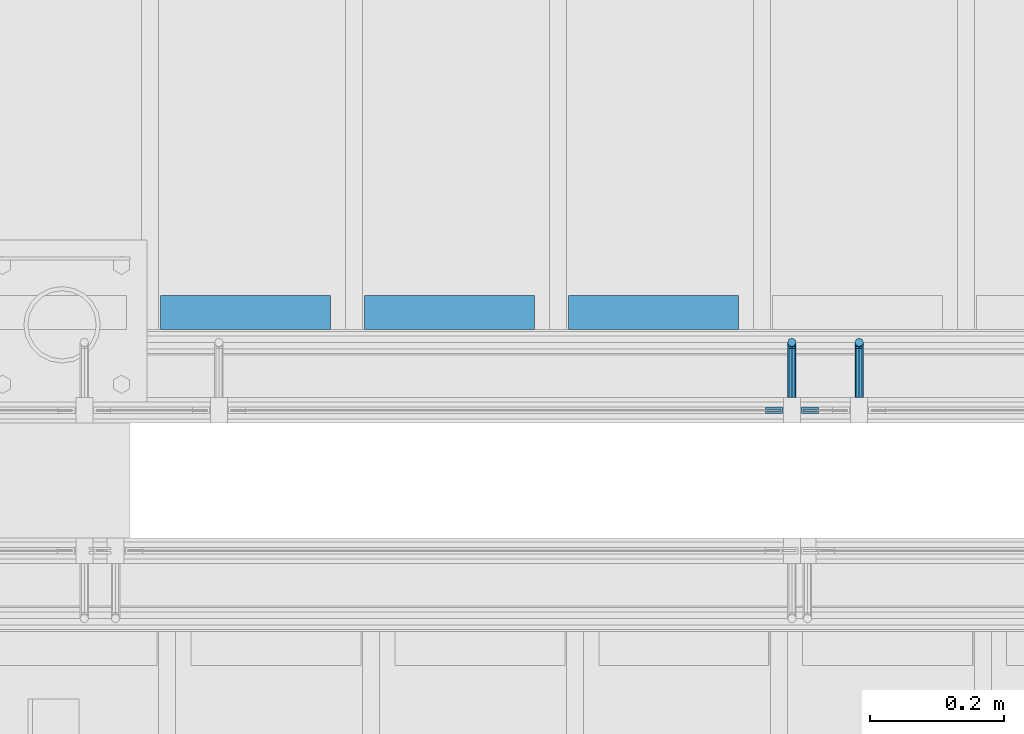
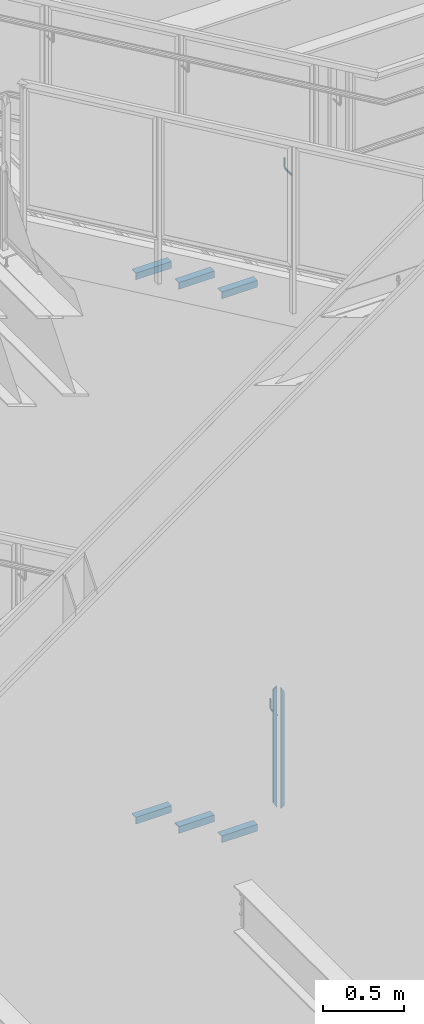
# One storey, part 939 of 1179: 10 beams, 4 elements without a shape of their own.
"""IFC2X3 building model written with IfcOpenShell, lengths in millimetres."""

from ifc_helpers import new_model, si_unit, frame, origin_with_axes, place, context, subcontext, project, spatial, faceted_brep, material, type_object, element, aggregate, save


model = new_model("IFC2X3")

# Units and contexts
model_context = context("Model", 3, precision=1e-05, world=origin_with_axes())
body_context = subcontext(model_context, "Body", "Model", "MODEL_VIEW")
ifc_project = project(units=[si_unit("LENGTHUNIT", "METRE", prefix="MILLI"), si_unit("AREAUNIT", "SQUARE_METRE"), si_unit("VOLUMEUNIT", "CUBIC_METRE"), si_unit("MASSUNIT", "GRAM", prefix="KILO"), si_unit("TIMEUNIT", "SECOND"), si_unit("PLANEANGLEUNIT", "RADIAN"), si_unit("SOLIDANGLEUNIT", "STERADIAN"), si_unit("THERMODYNAMICTEMPERATUREUNIT", "DEGREE_CELSIUS"), si_unit("LUMINOUSINTENSITYUNIT", "LUMEN")], contexts=[model_context])

# Site, building, storey
site_placement = place(None, origin_with_axes())
site = spatial("IfcSite", under=ifc_project, at=site_placement, CompositionType="ELEMENT")
building_placement = place(site_placement, origin_with_axes())
building = spatial("IfcBuilding", under=site, at=building_placement, Name="Undefined", CompositionType="ELEMENT")
storey_placement = place(building_placement, origin_with_axes())
storey = spatial("IfcBuildingStorey", under=building, at=storey_placement, Name="Undefined", CompositionType="ELEMENT", Elevation=0.0)

# Assembly, beams
assembly_1_placement = place(storey_placement, origin_with_axes())
assembly_1 = element("IfcElementAssembly", 1, at=assembly_1_placement, inside=storey, Name="GUARDRAIL", AssemblyPlace="NOTDEFINED", PredefinedType="RIGID_FRAME")
ifc_material_1 = material(Name="STEEL/BUY-OUT")
beam_type_1 = type_object("IfcBeamType", PredefinedType="NOTDEFINED")
beam_1_placement = place(assembly_1_placement, frame((21626.5124246046, 39677.9751661867, 3578.53056841568), z_axis=(0.0, 0.0, -1.0), x_axis=(1.0, 0.0, 0.0)))
beam_1 = element("IfcBeam", 2, at=beam_1_placement, type_object=beam_type_1, material=ifc_material_1, Name="U-EDGE", context=body_context, shape_type="Brep", body=[
    faceted_brep([(0.0, 1.58750000000146, 410.762302941614), (25.400000000016, 1.58750000000146, 454.819), (25.400000000016, 1.58750000000146, -454.819), (0.0, 1.58750000000146, -440.175144311391), (0.0, -1.58750000000146, 410.762302941614), (0.0, -1.58750000000146, -440.175144311391), (22.2250000000131, -1.58750000000146, 449.311912867583), (22.2250000000131, -1.58750000000146, -452.988518038564), (22.2250000000131, -4.76249999999709, 449.311912867583), (22.2250000000131, -4.76249999999709, -452.988518038564), (2.91038304567337e-11, -4.76249999999709, 410.762302941664), (2.91038304567337e-11, -4.76249999999709, -440.175144311408), (2.91038304567337e-11, -7.9375, 410.762302941664), (2.91038304567337e-11, -7.9375, -440.175144311408), (25.400000000016, -7.9375, 454.819), (25.400000000016, -7.9375, -454.819)], [[[0, 1, 2, 3]], [[4, 0, 3, 5]], [[6, 4, 5, 7]], [[8, 6, 7, 9]], [[10, 8, 9, 11]], [[12, 10, 11, 13]], [[14, 12, 13, 15]], [[11, 9, 7, 5, 3, 2, 15, 13]], [[1, 14, 15, 2]], [[0, 4, 6, 8, 10, 12, 14, 1]]]),
])
beam_2_placement = place(assembly_1_placement, frame((21705.5830340909, 39677.9751661867, 3562.16208185029), z_axis=(0.0, 0.0, -1.0), x_axis=(-1.0, 0.0, 0.0)))
beam_2 = element("IfcBeam", 3, at=beam_2_placement, type_object=beam_type_1, material=ifc_material_1, Name="U-EDGE", context=body_context, shape_type="Brep", body=[
    faceted_brep([(2.91038304567337e-11, 7.9375, 440.175302877862), (25.3999999999687, 7.9375, 454.819), (25.400000000016, 7.9375, -454.819), (2.91038304567337e-11, 7.9375, -410.76229705665), (2.91038304567337e-11, 4.76249999999709, 440.175302877862), (2.91038304567337e-11, 4.76249999999709, -410.76229705665), (22.2250000000131, 4.76249999999709, 452.988538277322), (22.2250000000131, 4.76249999999709, -449.311912132071), (22.2250000000131, 1.58750000000146, 452.988538277322), (22.2250000000131, 1.58750000000146, -449.311912132071), (0.0, 1.58750000000146, 440.175302877845), (0.0, 1.58750000000146, -410.7622970566), (0.0, -1.58750000000146, 440.175302877845), (0.0, -1.58750000000146, -410.7622970566), (25.3999999999687, -1.58750000000146, 454.819), (25.400000000016, -1.58750000000146, -454.819)], [[[0, 1, 2, 3]], [[4, 0, 3, 5]], [[6, 4, 5, 7]], [[8, 6, 7, 9]], [[10, 8, 9, 11]], [[12, 10, 11, 13]], [[14, 12, 13, 15]], [[11, 9, 7, 5, 3, 2, 15, 13]], [[1, 14, 15, 2]], [[0, 4, 6, 8, 10, 12, 14, 1]]]),
])

assembly_2_placement = place(storey_placement, origin_with_axes())
assembly_2 = element("IfcElementAssembly", 4, at=assembly_2_placement, inside=storey, Name="STAIR", AssemblyPlace="NOTDEFINED", PredefinedType="RIGID_FRAME")
ifc_material_2 = material(Name="STEEL/A36")
beam_type_2 = type_object("IfcBeamType", Name="L2X2X3/16", PredefinedType="NOTDEFINED")
beam_3_placement = place(assembly_2_placement, frame((20976.8321735073, 39827.200000038, 3274.28488298651), z_axis=(0.0, 1.0, 0.0), x_axis=(-1.0, 0.0, 0.0)))
beam_3 = element("IfcBeam", 5, at=beam_3_placement, type_object=beam_type_2, material=ifc_material_2, Name="ANGLE", ObjectType="L2X2X3/16", context=body_context, shape_type="Brep", body=[
    faceted_brep([(0.0, 25.3999999999996, -25.4000000000015), (0.0, 25.3999999999996, 25.4000000000015), (254.0, 25.3999999999996, 25.4000000000001), (254.0, 25.3999999999996, -25.4000000000001), (0.0, 20.6374999999998, 25.4000000000015), (254.0, 20.6374999999998, 25.4000000000001), (0.0, 20.6374999999998, -20.6374999999971), (254.0, 20.6374999999998, -20.6374999999998), (0.0, -25.3999999999996, -20.6374999999971), (254.0, -25.3999999999996, -20.6374999999998), (0.0, -25.3999999999996, -25.4000000000015), (254.0, -25.3999999999996, -25.4000000000001)], [[[0, 1, 2, 3]], [[1, 4, 5, 2]], [[4, 6, 7, 5]], [[6, 8, 9, 7]], [[8, 10, 11, 9]], [[10, 0, 3, 11]], [[5, 7, 9, 11, 3, 2]], [[10, 8, 6, 4, 1, 0]]]),
])
beam_4_placement = place(assembly_2_placement, frame((21281.6321734999, 39827.2000000358, 3097.8077997028), z_axis=(0.0, 1.0, 0.0), x_axis=(-1.0, 0.0, 0.0)))
beam_4 = element("IfcBeam", 6, at=beam_4_placement, type_object=beam_type_2, material=ifc_material_2, Name="ANGLE", ObjectType="L2X2X3/16", context=body_context, shape_type="Brep", body=[
    faceted_brep([(0.0, 25.3999999999996, -25.4000000000015), (0.0, 25.3999999999996, 25.4000000000015), (254.0, 25.3999999999996, 25.4000000000001), (254.0, 25.3999999999996, -25.4000000000001), (0.0, 20.6374999999998, 25.4000000000015), (254.0, 20.6374999999998, 25.4000000000001), (0.0, 20.6374999999998, -20.6374999999971), (254.0, 20.6374999999998, -20.6374999999998), (0.0, -25.3999999999996, -20.6374999999971), (254.0, -25.3999999999996, -20.6374999999998), (0.0, -25.3999999999996, -25.4000000000015), (254.0, -25.3999999999996, -25.4000000000001)], [[[0, 1, 2, 3]], [[1, 4, 5, 2]], [[4, 6, 7, 5]], [[6, 8, 9, 7]], [[8, 10, 11, 9]], [[10, 0, 3, 11]], [[5, 7, 9, 11, 3, 2]], [[10, 8, 6, 4, 1, 0]]]),
])
beam_5_placement = place(assembly_2_placement, frame((21586.4321734924, 39827.2000000336, 2921.33071641909), z_axis=(0.0, 1.0, 0.0), x_axis=(-1.0, 0.0, 0.0)))
beam_5 = element("IfcBeam", 7, at=beam_5_placement, type_object=beam_type_2, material=ifc_material_2, Name="ANGLE", ObjectType="L2X2X3/16", context=body_context, shape_type="Brep", body=[
    faceted_brep([(0.0, 25.3999999999996, -25.4000000000015), (0.0, 25.3999999999996, 25.4000000000015), (254.0, 25.3999999999996, 25.4000000000001), (254.0, 25.3999999999996, -25.4000000000001), (0.0, 20.6374999999998, 25.4000000000015), (254.0, 20.6374999999998, 25.4000000000001), (0.0, 20.6374999999998, -20.6374999999971), (254.0, 20.6374999999998, -20.6374999999998), (0.0, -25.3999999999996, -20.6374999999971), (254.0, -25.3999999999996, -20.6374999999998), (0.0, -25.3999999999996, -25.4000000000015), (254.0, -25.3999999999996, -25.4000000000001)], [[[0, 1, 2, 3]], [[1, 4, 5, 2]], [[4, 6, 7, 5]], [[6, 8, 9, 7]], [[8, 10, 11, 9]], [[10, 0, 3, 11]], [[5, 7, 9, 11, 3, 2]], [[10, 8, 6, 4, 1, 0]]]),
])
aggregate(assembly_2, [beam_3, beam_4, beam_5])

assembly_3_placement = place(storey_placement, origin_with_axes())
assembly_3 = element("IfcElementAssembly", 8, at=assembly_3_placement, inside=storey, Name="STAIR", AssemblyPlace="NOTDEFINED", PredefinedType="RIGID_FRAME")
beam_6_placement = place(assembly_3_placement, frame((20976.8869685408, 39827.2000000125, 7357.07030000811), z_axis=(0.0, 1.0, 0.0), x_axis=(-1.0, 0.0, 0.0)))
beam_6 = element("IfcBeam", 9, at=beam_6_placement, type_object=beam_type_2, material=ifc_material_2, Name="ANGLE", ObjectType="L2X2X3/16", context=body_context, shape_type="Brep", body=[
    faceted_brep([(0.0, 25.3999999999996, -25.4000000000015), (0.0, 25.3999999999996, 25.4000000000015), (254.0, 25.3999999999996, 25.4000000000001), (254.0, 25.3999999999996, -25.4000000000001), (0.0, 20.6374999999998, 25.4000000000015), (254.0, 20.6374999999998, 25.4000000000001), (0.0, 20.6374999999998, -20.6374999999971), (254.0, 20.6374999999998, -20.6374999999998), (0.0, -25.3999999999996, -20.6374999999971), (254.0, -25.3999999999996, -20.6374999999998), (0.0, -25.3999999999996, -25.4000000000015), (254.0, -25.3999999999996, -25.4000000000001)], [[[0, 1, 2, 3]], [[1, 4, 5, 2]], [[4, 6, 7, 5]], [[6, 8, 9, 7]], [[8, 10, 11, 9]], [[10, 0, 3, 11]], [[5, 7, 9, 11, 3, 2]], [[10, 8, 6, 4, 1, 0]]]),
])
beam_7_placement = place(assembly_3_placement, frame((21281.6869682887, 39827.2000000125, 7179.27030000811), z_axis=(0.0, 1.0, 0.0), x_axis=(-1.0, 0.0, 0.0)))
beam_7 = element("IfcBeam", 10, at=beam_7_placement, type_object=beam_type_2, material=ifc_material_2, Name="ANGLE", ObjectType="L2X2X3/16", context=body_context, shape_type="Brep", body=[
    faceted_brep([(0.0, 25.3999999999996, -25.4000000000015), (0.0, 25.3999999999996, 25.4000000000015), (254.0, 25.3999999999996, 25.4000000000001), (254.0, 25.3999999999996, -25.4000000000001), (0.0, 20.6374999999998, 25.4000000000015), (254.0, 20.6374999999998, 25.4000000000001), (0.0, 20.6374999999998, -20.6374999999971), (254.0, 20.6374999999998, -20.6374999999998), (0.0, -25.3999999999996, -20.6374999999971), (254.0, -25.3999999999996, -20.6374999999998), (0.0, -25.3999999999996, -25.4000000000015), (254.0, -25.3999999999996, -25.4000000000001)], [[[0, 1, 2, 3]], [[1, 4, 5, 2]], [[4, 6, 7, 5]], [[6, 8, 9, 7]], [[8, 10, 11, 9]], [[10, 0, 3, 11]], [[5, 7, 9, 11, 3, 2]], [[10, 8, 6, 4, 1, 0]]]),
])
beam_8_placement = place(assembly_3_placement, frame((21586.4869680367, 39827.2000000125, 7001.47030000811), z_axis=(0.0, 1.0, 0.0), x_axis=(-1.0, 0.0, 0.0)))
beam_8 = element("IfcBeam", 11, at=beam_8_placement, type_object=beam_type_2, material=ifc_material_2, Name="ANGLE", ObjectType="L2X2X3/16", context=body_context, shape_type="Brep", body=[
    faceted_brep([(0.0, 25.3999999999996, -25.4000000000015), (0.0, 25.3999999999996, 25.4000000000015), (254.0, 25.3999999999996, 25.4000000000001), (254.0, 25.3999999999996, -25.4000000000001), (0.0, 20.6374999999998, 25.4000000000015), (254.0, 20.6374999999998, 25.4000000000001), (0.0, 20.6374999999998, -20.6374999999971), (254.0, 20.6374999999998, -20.6374999999998), (0.0, -25.3999999999996, -20.6374999999971), (254.0, -25.3999999999996, -20.6374999999998), (0.0, -25.3999999999996, -25.4000000000015), (254.0, -25.3999999999996, -25.4000000000001)], [[[0, 1, 2, 3]], [[1, 4, 5, 2]], [[4, 6, 7, 5]], [[6, 8, 9, 7]], [[8, 10, 11, 9]], [[10, 0, 3, 11]], [[5, 7, 9, 11, 3, 2]], [[10, 8, 6, 4, 1, 0]]]),
])
aggregate(assembly_3, [beam_6, beam_7, beam_8])

# Assembly, beam
assembly_4_placement = place(storey_placement, origin_with_axes())
assembly_4 = element("IfcElementAssembly", 12, at=assembly_4_placement, inside=storey, Name="GUARDRAIL", AssemblyPlace="NOTDEFINED", PredefinedType="RIGID_FRAME")
beam_type_3 = type_object("IfcBeamType", PredefinedType="NOTDEFINED")
beam_9_placement = place(assembly_4_placement, frame((21766.7416677555, 39700.2000007796, 7819.22561089747), z_axis=(0.0, 0.0, 1.0), x_axis=(0.0, 1.0, 0.0)))
beam_9 = element("IfcBeam", 13, at=beam_9_placement, type_object=beam_type_3, material=ifc_material_2, Name="BRACKET", context=body_context, shape_type="Brep", body=[
    faceted_brep([(0.0, 0.0, 6.34999999999991), (0.0, -4.49012806053361, 4.49012806053452), (69.849999425729, -4.49012806053361, 4.49012806053452), (69.849999425729, 0.0, 6.34999999999991), (0.0, 4.49012806053361, 4.49012806053452), (69.849999425729, 4.49012806053361, 4.49012806053452), (0.0, 6.34999999999854, 0.0), (69.849999425729, 6.34999999999854, 0.0), (0.0, 4.49012806053361, -4.49012806053452), (69.849999425729, 4.49012806053361, -4.49012806053452), (0.0, 0.0, -6.34999999999991), (69.849999425729, 0.0, -6.34999999999991), (0.0, -4.49012806053361, -4.49012806053452), (69.849999425729, -4.49012806053361, -4.49012806053452), (0.0, -6.34999999999854, 0.0), (69.849999425729, -6.34999999999854, 0.0), (76.1999993303689, -6.34999999999854, 1.70147734638658), (73.9549353000984, -4.49012806053361, 5.59004231305425), (73.024999330366, 0.0, 7.20073866041639), (73.9549353000984, 4.49012806053361, 5.59004231305425), (76.1999993303689, 6.34999999999854, 1.70147734638658), (78.445063360632, 4.49012806053361, -2.18708762028064), (79.3749993303718, 0.0, -3.79778396764323), (78.445063360632, -4.49012806053361, -2.18708762028064), (84.7370868552753, 4.49012806053361, 4.10493587436031), (87.0401272955278, 4.49012806053361, 12.6999998092651), (88.8999992349927, 0.0, 12.6999998092651), (86.3477832026401, 0.0, 3.17499990462693), (80.8485218886053, 6.34999999999854, 6.34999990462893), (82.5499992349942, 6.34999999999854, 12.6999998092651), (76.9599569219426, 4.49012806053361, 8.59506393489755), (78.0598711744606, 4.49012806053361, 12.6999998092651), (75.3492605745778, 0.0, 9.52499990463093), (76.1999992349956, 0.0, 12.6999998092651), (76.9599569219426, -4.49012806053361, 8.59506393489755), (78.0598711744606, -4.49012806053361, 12.6999998092651), (80.8485218886053, -6.34999999999854, 6.34999990462893), (82.5499992349942, -6.34999999999854, 12.6999998092651), (84.7370868552753, -4.49012806053361, 4.10493587436031), (87.0401272955278, -4.49012806053361, 12.6999998092651), (88.8999992349927, 0.0, 76.2000000000003), (87.0401272955278, -4.49012806053361, 73.5797637174637), (82.5499992349942, -6.34999999999854, 72.4944263126154), (78.0598711744606, -4.49012806053361, 73.5797637174637), (76.1999992349956, 0.0, 76.2000000000003), (78.0598711744606, 4.49012806053361, 78.8202362825368), (82.5499992349942, 6.34999999999854, 79.8943188022276), (87.0401272955278, 4.49012806053361, 78.8202362825368)], [[[0, 1, 2, 3]], [[4, 0, 3, 5]], [[6, 4, 5, 7]], [[8, 6, 7, 9]], [[10, 8, 9, 11]], [[12, 10, 11, 13]], [[1, 0, 4, 6, 8, 10, 12, 14]], [[1, 14, 15, 2]], [[14, 12, 13, 15]], [[2, 15, 16, 17]], [[3, 2, 17, 18]], [[5, 3, 18, 19]], [[7, 5, 19, 20]], [[9, 7, 20, 21]], [[11, 9, 21, 22]], [[13, 11, 22, 23]], [[24, 25, 26, 27]], [[28, 29, 25, 24]], [[30, 31, 29, 28]], [[32, 33, 31, 30]], [[34, 35, 33, 32]], [[36, 37, 35, 34]], [[38, 39, 37, 36]], [[27, 26, 39, 38]], [[22, 27, 38, 23]], [[21, 24, 27, 22]], [[20, 28, 24, 21]], [[19, 30, 28, 20]], [[18, 32, 30, 19]], [[17, 34, 32, 18]], [[16, 36, 34, 17]], [[23, 38, 36, 16]], [[15, 13, 23, 16]], [[39, 26, 40, 41]], [[37, 39, 41, 42]], [[35, 37, 42, 43]], [[33, 35, 43, 44]], [[31, 33, 44, 45]], [[29, 31, 45, 46]], [[25, 29, 46, 47]], [[26, 25, 47, 40]], [[46, 45, 44, 43, 42, 41, 40, 47]]]),
])
aggregate(assembly_4, [beam_9])

# Beam
beam_10_placement = place(assembly_1_placement, frame((21666.1999246046, 39700.2000007745, 3797.91473671854), z_axis=(0.0, 0.0, 1.0), x_axis=(0.0, 1.0, 0.0)))
beam_10 = element("IfcBeam", 14, at=beam_10_placement, type_object=beam_type_3, material=ifc_material_2, Name="BRACKET", context=body_context, shape_type="Brep", body=[
    faceted_brep([(0.0, 0.0, 6.34999999999991), (0.0, -4.49012806053361, 4.49012806053452), (69.849999425729, -4.49012806053361, 4.49012806053452), (69.849999425729, 0.0, 6.34999999999991), (0.0, 4.49012806053361, 4.49012806053452), (69.849999425729, 4.49012806053361, 4.49012806053452), (0.0, 6.34999999999854, 0.0), (69.849999425729, 6.34999999999854, 0.0), (0.0, 4.49012806053361, -4.49012806053452), (69.849999425729, 4.49012806053361, -4.49012806053452), (0.0, 0.0, -6.34999999999991), (69.849999425729, 0.0, -6.34999999999991), (0.0, -4.49012806053361, -4.49012806053452), (69.849999425729, -4.49012806053361, -4.49012806053452), (0.0, -6.34999999999854, 0.0), (69.849999425729, -6.34999999999854, 0.0), (76.1999993303689, -6.34999999999854, 1.70147734638658), (73.9549353000984, -4.49012806053361, 5.59004231305425), (73.024999330366, 0.0, 7.20073866041639), (73.9549353000984, 4.49012806053361, 5.59004231305425), (76.1999993303689, 6.34999999999854, 1.70147734638658), (78.445063360632, 4.49012806053361, -2.18708762028064), (79.3749993303718, 0.0, -3.79778396764323), (78.445063360632, -4.49012806053361, -2.18708762028064), (84.7370868552753, 4.49012806053361, 4.10493587436031), (87.0401272955278, 4.49012806053361, 12.6999998092651), (88.8999992349927, 0.0, 12.6999998092651), (86.3477832026401, 0.0, 3.17499990462693), (80.8485218886053, 6.34999999999854, 6.34999990462893), (82.5499992349942, 6.34999999999854, 12.6999998092651), (76.9599569219426, 4.49012806053361, 8.59506393489755), (78.0598711744606, 4.49012806053361, 12.6999998092651), (75.3492605745778, 0.0, 9.52499990463093), (76.1999992349956, 0.0, 12.6999998092651), (76.9599569219426, -4.49012806053361, 8.59506393489755), (78.0598711744606, -4.49012806053361, 12.6999998092651), (80.8485218886053, -6.34999999999854, 6.34999990462893), (82.5499992349942, -6.34999999999854, 12.6999998092651), (84.7370868552753, -4.49012806053361, 4.10493587436031), (87.0401272955278, -4.49012806053361, 12.6999998092651), (88.8999992349927, 0.0, 76.2000000000003), (87.0401272955278, -4.49012806053361, 73.5797637174637), (82.5499992349942, -6.34999999999854, 72.4944263126154), (78.0598711744606, -4.49012806053361, 73.5797637174637), (76.1999992349956, 0.0, 76.2000000000003), (78.0598711744606, 4.49012806053361, 78.8202362825368), (82.5499992349942, 6.34999999999854, 79.8943188022276), (87.0401272955278, 4.49012806053361, 78.8202362825368)], [[[0, 1, 2, 3]], [[4, 0, 3, 5]], [[6, 4, 5, 7]], [[8, 6, 7, 9]], [[10, 8, 9, 11]], [[12, 10, 11, 13]], [[1, 0, 4, 6, 8, 10, 12, 14]], [[1, 14, 15, 2]], [[14, 12, 13, 15]], [[2, 15, 16, 17]], [[3, 2, 17, 18]], [[5, 3, 18, 19]], [[7, 5, 19, 20]], [[9, 7, 20, 21]], [[11, 9, 21, 22]], [[13, 11, 22, 23]], [[24, 25, 26, 27]], [[28, 29, 25, 24]], [[30, 31, 29, 28]], [[32, 33, 31, 30]], [[34, 35, 33, 32]], [[36, 37, 35, 34]], [[38, 39, 37, 36]], [[27, 26, 39, 38]], [[22, 27, 38, 23]], [[21, 24, 27, 22]], [[20, 28, 24, 21]], [[19, 30, 28, 20]], [[18, 32, 30, 19]], [[17, 34, 32, 18]], [[16, 36, 34, 17]], [[23, 38, 36, 16]], [[15, 13, 23, 16]], [[39, 26, 40, 41]], [[37, 39, 41, 42]], [[35, 37, 42, 43]], [[33, 35, 43, 44]], [[31, 33, 44, 45]], [[29, 31, 45, 46]], [[25, 29, 46, 47]], [[26, 25, 47, 40]], [[46, 45, 44, 43, 42, 41, 40, 47]]]),
])

aggregate(assembly_1, [beam_1, beam_2, beam_10])

save(model, "model.ifc")
